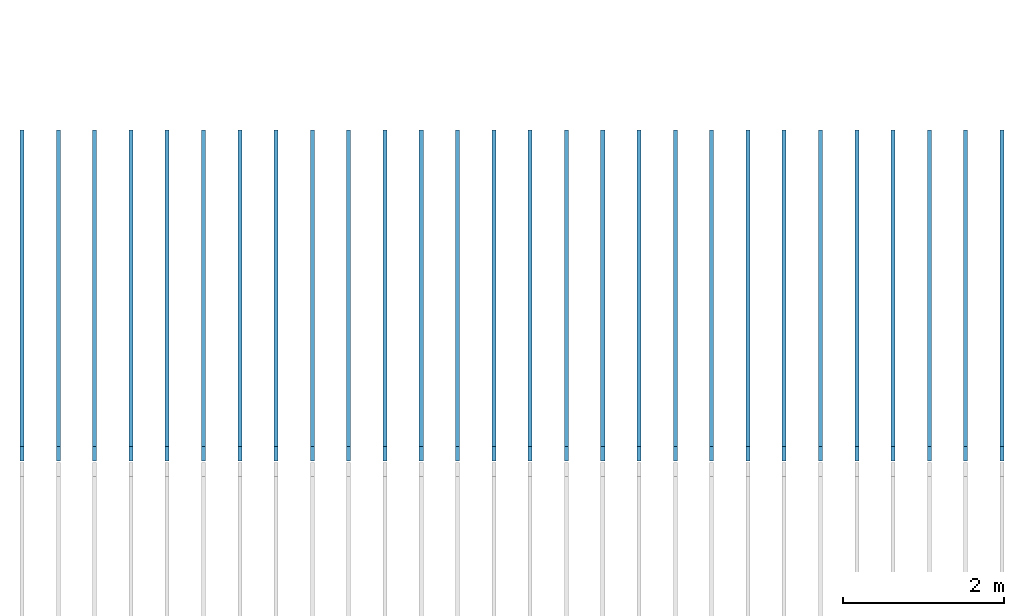
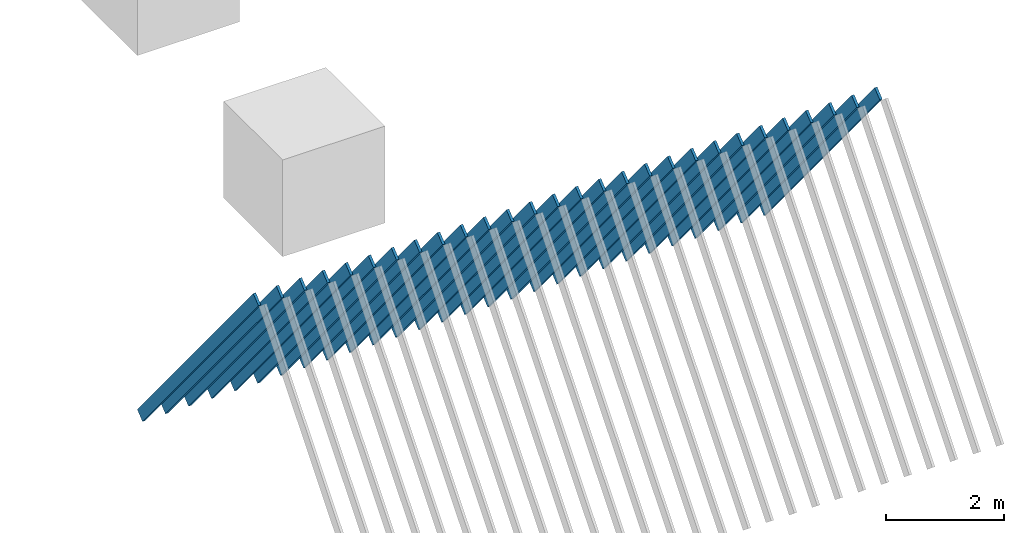
# Not in any storey, part 2 of 4: 1 roof.
"""IFC4 model written with IfcOpenShell, lengths in metres."""

from ifc_helpers import new_model, entity, si_unit, converted_unit, frame, frame_2d, origin_with_axes, place, context, project, polygons, shape, element, save


model = new_model("IFC4")

# Units and contexts
model_context = context("Model", 3, precision=1e-05, world=origin_with_axes())
plan_context = context("Plan", 2, precision=1e-05, world=frame_2d((0.0, 0.0, 0.0), x_axis=(1.0, 0.0, 0.0)))
ifc_project = project(units=[si_unit("AREAUNIT", "SQUARE_METRE"), si_unit("VOLUMEUNIT", "CUBIC_METRE"), si_unit("LENGTHUNIT", "METRE"), converted_unit("PLANEANGLEUNIT", "degree", entity("IfcReal", 0.0174532925199433), si_unit("PLANEANGLEUNIT", "RADIAN"), dimensions=[0, 0, 0, 0, 0, 0, 0])], contexts=[model_context, plan_context])

# Roof
roof_placement = place(None, frame((-7.88622856140137, -10.0965747833252, 4.8522891998291), z_axis=(1.0, -7.11335474079533e-07, -2.5490300004094e-07), x_axis=(-2.5490300004094e-07, -0.635131001472473, 0.772404432296753)))
element("IfcRoof", 1, at=roof_placement, Name="Roof_Joists.001", PredefinedType="BARREL_ROOF", shapes=[
    shape(model_context, None, "Tessellation", [polygons([(3.09032249450684, -0.114181444048882, 0.025000000372529), (3.09032249450684, 0.114181444048882, 0.025000000372529), (-3.09032249450684, -0.114181444048882, 0.025000000372529), (-3.09032249450684, 0.114181444048882, 0.025000000372529), (3.09032249450684, 0.114181444048882, -0.025000000372529), (3.09032249450684, -0.114181444048882, -0.025000000372529), (-3.09032249450684, 0.114181444048882, 0.474999994039536), (3.09032249450684, 0.114181444048882, 0.474999994039536), (-3.09032249450684, 0.114181444048882, 0.424999982118607), (3.09032249450684, 0.114181444048882, 0.424999982118607), (-3.09032249450684, 0.114181444048882, -0.025000000372529), (-3.09032249450684, -0.114181444048882, -0.025000000372529), (3.09032249450684, -0.114181444048882, 0.424999982118607), (-3.09032249450684, -0.114181444048882, 0.424999982118607), (-3.09032249450684, -0.114181444048882, 0.474999994039536), (3.09032249450684, -0.114181444048882, 0.474999994039536), (3.09032249450684, -0.114181444048882, 0.875), (-3.09032249450684, -0.114181444048882, 0.875), (-3.09032249450684, -0.114181444048882, 0.924999952316284), (3.09032249450684, -0.114181444048882, 0.924999952316284), (-3.09032249450684, 0.114181444048882, 0.924999952316284), (3.09032249450684, 0.114181444048882, 0.924999952316284), (-3.09032249450684, 0.114181444048882, 0.875), (3.09032249450684, 0.114181444048882, 0.875), (3.09032249450684, -0.114181444048882, 1.32499992847443), (-3.09032249450684, -0.114181444048882, 1.32499992847443), (-3.09032249450684, -0.114181444048882, 1.37499988079071), (3.09032249450684, -0.114181444048882, 1.37499988079071), (-3.09032249450684, 0.114181444048882, 1.37499988079071), (3.09032249450684, 0.114181444048882, 1.37499988079071), (-3.09032249450684, 0.114181444048882, 1.32499992847443), (3.09032249450684, 0.114181444048882, 1.32499992847443), (3.09032249450684, -0.114181444048882, 1.77499997615814), (-3.09032249450684, -0.114181444048882, 1.77499997615814), (-3.09032249450684, -0.114181444048882, 1.82499992847443), (3.09032249450684, -0.114181444048882, 1.82499992847443), (-3.09032249450684, 0.114181444048882, 1.82499992847443), (3.09032249450684, 0.114181444048882, 1.82499992847443), (-3.09032249450684, 0.114181444048882, 1.77499997615814), (3.09032249450684, 0.114181444048882, 1.77499997615814), (3.09032249450684, -0.114181444048882, 2.27500009536743), (3.09032249450684, 0.114181444048882, 2.27500009536743), (-3.09032249450684, -0.114181444048882, 2.27500009536743), (-3.09032249450684, 0.114181444048882, 2.27500009536743), (-3.09032249450684, 0.114181444048882, 2.72500014305115), (3.09032249450684, 0.114181444048882, 2.72500014305115), (-3.09032249450684, 0.114181444048882, 2.67499995231628), (3.09032249450684, 0.114181444048882, 2.67499995231628), (3.09032249450684, -0.114181444048882, 2.22499990463257), (-3.09032249450684, -0.114181444048882, 2.22499990463257), (3.09032249450684, 0.114181444048882, 2.22499990463257), (-3.09032249450684, 0.114181444048882, 2.22499990463257), (3.09032249450684, -0.114181444048882, 2.67499995231628), (-3.09032249450684, -0.114181444048882, 2.67499995231628), (-3.09032249450684, -0.114181444048882, 2.72500014305115), (3.09032249450684, -0.114181444048882, 2.72500014305115), (3.09032249450684, 0.114181444048882, 4.07500028610229), (3.09032249450684, 0.114181444048882, 4.02500009536743), (-3.09032249450684, 0.114181444048882, 4.07500028610229), (-3.09032249450684, 0.114181444048882, 4.02500009536743), (3.09032249450684, -0.114181444048882, 3.125), (-3.09032249450684, -0.114181444048882, 3.125), (-3.09032249450684, -0.114181444048882, 3.17500019073486), (3.09032249450684, -0.114181444048882, 3.17500019073486), (-3.09032249450684, 0.114181444048882, 3.17500019073486), (3.09032249450684, 0.114181444048882, 3.17500019073486), (-3.09032249450684, 0.114181444048882, 3.125), (3.09032249450684, 0.114181444048882, 3.125), (3.09032249450684, -0.114181444048882, 3.57500004768372), (-3.09032249450684, -0.114181444048882, 3.57500004768372), (-3.09032249450684, -0.114181444048882, 3.62500023841858), (3.09032249450684, -0.114181444048882, 3.62500023841858), (-3.09032249450684, 0.114181444048882, 3.62500023841858), (3.09032249450684, 0.114181444048882, 3.62500023841858), (-3.09032249450684, 0.114181444048882, 3.57500004768372), (3.09032249450684, 0.114181444048882, 3.57500004768372), (3.09032249450684, -0.114181444048882, 4.02500009536743), (-3.09032249450684, -0.114181444048882, 4.02500009536743), (-3.09032249450684, -0.114181444048882, 4.07500028610229), (3.09032249450684, -0.114181444048882, 4.07500028610229), (-3.09032249450684, 0.114181444048882, 4.97499990463257), (3.09032249450684, 0.114181444048882, 4.97499990463257), (-3.09032249450684, 0.114181444048882, 4.92499971389771), (3.09032249450684, 0.114181444048882, 4.92499971389771), (3.09032249450684, -0.114181444048882, 4.52500009536743), (3.09032249450684, 0.114181444048882, 4.52500009536743), (-3.09032249450684, -0.114181444048882, 4.52500009536743), (-3.09032249450684, 0.114181444048882, 4.52500009536743), (3.09032249450684, 0.114181444048882, 4.47499990463257), (-3.09032249450684, 0.114181444048882, 4.47499990463257), (3.09032249450684, -0.114181444048882, 4.47499990463257), (-3.09032249450684, -0.114181444048882, 4.47499990463257), (3.09032249450684, -0.114181444048882, 4.97499990463257), (-3.09032249450684, -0.114181444048882, 4.97499990463257), (3.09032249450684, 0.114181444048882, 9.92499732971191), (3.09032249450684, 0.114181444048882, 9.87499809265137), (-3.09032249450684, 0.114181444048882, 9.92499732971191), (-3.09032249450684, 0.114181444048882, 9.87499809265137), (3.09032249450684, -0.114181444048882, 4.92499971389771), (-3.09032249450684, -0.114181444048882, 4.92499971389771), (3.09032249450684, -0.114181444048882, 5.37499952316284), (-3.09032249450684, -0.114181444048882, 5.37499952316284), (-3.09032249450684, -0.114181444048882, 5.42499971389771), (3.09032249450684, -0.114181444048882, 5.42499971389771), (-3.09032249450684, 0.114181444048882, 5.42499971389771), (3.09032249450684, 0.114181444048882, 5.42499971389771), (-3.09032249450684, 0.114181444048882, 5.37499952316284), (3.09032249450684, 0.114181444048882, 5.37499952316284), (3.09032249450684, -0.114181444048882, 5.87499952316284), (3.09032249450684, 0.114181444048882, 5.87499952316284), (-3.09032249450684, -0.114181444048882, 5.87499952316284), (-3.09032249450684, 0.114181444048882, 5.87499952316284), (-3.09032249450684, 0.114181444048882, 5.82499933242798), (3.09032249450684, 0.114181444048882, 5.82499933242798), (3.09032249450684, -0.114181444048882, 5.82499933242798), (-3.09032249450684, -0.114181444048882, 5.82499933242798), (3.09032249450684, -0.114181444048882, 6.27499914169312), (-3.09032249450684, -0.114181444048882, 6.27499914169312), (-3.09032249450684, -0.114181444048882, 6.32499933242798), (3.09032249450684, -0.114181444048882, 6.32499933242798), (-3.09032249450684, 0.114181444048882, 6.32499933242798), (3.09032249450684, 0.114181444048882, 6.32499933242798), (-3.09032249450684, 0.114181444048882, 6.27499914169312), (3.09032249450684, 0.114181444048882, 6.27499914169312), (3.09032249450684, -0.114181444048882, 6.72499895095825), (-3.09032249450684, -0.114181444048882, 6.72499895095825), (-3.09032249450684, -0.114181444048882, 6.77499914169312), (3.09032249450684, -0.114181444048882, 6.77499914169312), (-3.09032249450684, 0.114181444048882, 6.77499914169312), (3.09032249450684, 0.114181444048882, 6.77499914169312), (-3.09032249450684, 0.114181444048882, 6.72499895095825), (3.09032249450684, 0.114181444048882, 6.72499895095825), (3.09032249450684, -0.114181444048882, 7.17499876022339), (-3.09032249450684, -0.114181444048882, 7.17499876022339), (-3.09032249450684, -0.114181444048882, 7.22499895095825), (3.09032249450684, -0.114181444048882, 7.22499895095825), (-3.09032249450684, 0.114181444048882, 7.22499895095825), (3.09032249450684, 0.114181444048882, 7.22499895095825), (-3.09032249450684, 0.114181444048882, 7.17499876022339), (3.09032249450684, 0.114181444048882, 7.17499876022339), (3.09032249450684, -0.114181444048882, 7.67499876022339), (3.09032249450684, 0.114181444048882, 7.67499876022339), (-3.09032249450684, -0.114181444048882, 7.67499876022339), (-3.09032249450684, 0.114181444048882, 7.67499876022339), (-3.09032249450684, 0.114181444048882, 7.62499856948853), (3.09032249450684, 0.114181444048882, 7.62499856948853), (3.09032249450684, -0.114181444048882, 7.62499856948853), (-3.09032249450684, -0.114181444048882, 7.62499856948853), (3.09032249450684, -0.114181444048882, 8.07499885559082), (-3.09032249450684, -0.114181444048882, 8.07499885559082), (-3.09032249450684, -0.114181444048882, 8.12499809265137), (3.09032249450684, -0.114181444048882, 8.12499809265137), (-3.09032249450684, 0.114181444048882, 8.12499809265137), (3.09032249450684, 0.114181444048882, 8.12499809265137), (-3.09032249450684, 0.114181444048882, 8.07499885559082), (3.09032249450684, 0.114181444048882, 8.07499885559082), (3.09032249450684, -0.114181444048882, 8.52499866485596), (-3.09032249450684, -0.114181444048882, 8.52499866485596), (-3.09032249450684, -0.114181444048882, 8.5749979019165), (3.09032249450684, -0.114181444048882, 8.5749979019165), (-3.09032249450684, 0.114181444048882, 8.5749979019165), (3.09032249450684, 0.114181444048882, 8.5749979019165), (-3.09032249450684, 0.114181444048882, 8.52499866485596), (3.09032249450684, 0.114181444048882, 8.52499866485596), (3.09032249450684, -0.114181444048882, 8.97499847412109), (-3.09032249450684, -0.114181444048882, 8.97499847412109), (-3.09032249450684, -0.114181444048882, 9.02499771118164), (3.09032249450684, -0.114181444048882, 9.02499771118164), (-3.09032249450684, 0.114181444048882, 9.02499771118164), (3.09032249450684, 0.114181444048882, 9.02499771118164), (-3.09032249450684, 0.114181444048882, 8.97499847412109), (3.09032249450684, 0.114181444048882, 8.97499847412109), (3.09032249450684, -0.114181444048882, 9.42499828338623), (-3.09032249450684, -0.114181444048882, 9.42499828338623), (-3.09032249450684, -0.114181444048882, 9.47499752044678), (3.09032249450684, -0.114181444048882, 9.47499752044678), (-3.09032249450684, 0.114181444048882, 9.47499752044678), (3.09032249450684, 0.114181444048882, 9.47499752044678), (-3.09032249450684, 0.114181444048882, 9.42499828338623), (3.09032249450684, 0.114181444048882, 9.42499828338623), (3.09032249450684, -0.114181444048882, 9.92499732971191), (-3.09032249450684, -0.114181444048882, 9.92499732971191), (-3.09032249450684, 0.114181444048882, 10.3749971389771), (3.09032249450684, 0.114181444048882, 10.3749971389771), (-3.09032249450684, 0.114181444048882, 10.3249979019165), (3.09032249450684, 0.114181444048882, 10.3249979019165), (3.09032249450684, -0.114181444048882, 9.87499809265137), (-3.09032249450684, -0.114181444048882, 9.87499809265137), (3.09032249450684, -0.114181444048882, 10.3749971389771), (-3.09032249450684, -0.114181444048882, 10.3749971389771), (3.09032249450684, 0.114181444048882, 10.8249969482422), (3.09032249450684, 0.114181444048882, 10.7749977111816), (-3.09032249450684, 0.114181444048882, 10.8249969482422), (-3.09032249450684, 0.114181444048882, 10.7749977111816), (3.09032249450684, -0.114181444048882, 10.3249979019165), (-3.09032249450684, -0.114181444048882, 10.3249979019165), (3.09032249450684, -0.114181444048882, 10.8249969482422), (-3.09032249450684, -0.114181444048882, 10.8249969482422), (-3.09032249450684, 0.114181444048882, 11.2749967575073), (3.09032249450684, 0.114181444048882, 11.2749967575073), (-3.09032249450684, 0.114181444048882, 11.2249975204468), (3.09032249450684, 0.114181444048882, 11.2249975204468), (3.09032249450684, -0.114181444048882, 10.7749977111816), (-3.09032249450684, -0.114181444048882, 10.7749977111816), (3.09032249450684, -0.114181444048882, 11.2249975204468), (-3.09032249450684, -0.114181444048882, 11.2249975204468), (-3.09032249450684, -0.114181444048882, 11.2749967575073), (3.09032249450684, -0.114181444048882, 11.2749967575073), (3.09032249450684, 0.114181444048882, 11.7249965667725), (3.09032249450684, 0.114181444048882, 11.6749973297119), (-3.09032249450684, 0.114181444048882, 11.7249965667725), (-3.09032249450684, 0.114181444048882, 11.6749973297119), (3.09032249450684, -0.114181444048882, 11.7249965667725), (-3.09032249450684, -0.114181444048882, 11.7249965667725), (3.09032249450684, -0.114181444048882, 11.6749973297119), (-3.09032249450684, -0.114181444048882, 11.6749973297119), (3.09032249450684, -0.114181444048882, 12.1249971389771), (-3.09032249450684, -0.114181444048882, 12.1249971389771), (-3.09032249450684, -0.114181444048882, 12.1749963760376), (3.09032249450684, -0.114181444048882, 12.1749963760376), (-3.09032249450684, 0.114181444048882, 12.1749963760376), (-3.09032249450684, 0.114181444048882, 12.1249971389771), (3.09032249450684, 0.114181444048882, 12.1249971389771), (3.09032249450684, 0.114181444048882, 12.1749963760376)], [[[14, 9, 10, 13]], [[47, 54, 55, 45]], [[21, 22, 24, 23]], [[46, 56, 53, 48]], [[18, 17, 20, 19]], [[131, 126, 127, 129]], [[18, 23, 24, 17]], [[29, 30, 32, 31]], [[30, 28, 25, 32]], [[26, 25, 28, 27]], [[28, 30, 29, 27]], [[26, 31, 32, 25]], [[37, 38, 40, 39]], [[39, 34, 35, 37]], [[38, 36, 33, 40]], [[34, 33, 36, 35]], [[36, 38, 37, 35]], [[34, 39, 40, 33]], [[45, 46, 48, 47]], [[80, 57, 59, 79]], [[41, 42, 44, 43]], [[42, 41, 49, 51]], [[44, 42, 51, 52]], [[50, 49, 41, 43]], [[66, 64, 61, 68]], [[65, 66, 68, 67]], [[59, 57, 58, 60]], [[136, 138, 137, 135]], [[85, 86, 88, 87]], [[62, 61, 64, 63]], [[78, 60, 58, 77]], [[67, 62, 63, 65]], [[54, 53, 56, 55]], [[64, 66, 65, 63]], [[123, 118, 119, 121]], [[62, 67, 68, 61]], [[73, 74, 76, 75]], [[75, 70, 71, 73]], [[74, 72, 69, 76]], [[70, 69, 72, 71]], [[72, 74, 73, 71]], [[70, 75, 76, 69]], [[57, 80, 77, 58]], [[90, 92, 87, 88]], [[79, 78, 77, 80]], [[86, 85, 91, 89]], [[88, 86, 89, 90]], [[52, 50, 43, 44]], [[82, 93, 99, 84]], [[100, 83, 84, 99]], [[92, 90, 89, 91]], [[83, 81, 82, 84]], [[83, 100, 94, 81]], [[92, 91, 85, 87]], [[97, 95, 96, 98]], [[100, 99, 93, 94]], [[102, 101, 104, 103]], [[93, 82, 81, 94]], [[107, 102, 103, 105]], [[105, 106, 108, 107]], [[104, 106, 105, 103]], [[106, 104, 101, 108]], [[116, 113, 114, 115]], [[212, 216, 214, 211]], [[213, 209, 211, 214]], [[102, 107, 108, 101]], [[121, 122, 124, 123]], [[113, 116, 111, 112]], [[109, 110, 112, 111]], [[113, 112, 110, 114]], [[120, 122, 121, 119]], [[116, 115, 109, 111]], [[110, 109, 115, 114]], [[122, 120, 117, 124]], [[118, 117, 120, 119]], [[208, 200, 199, 207]], [[56, 46, 45, 55]], [[118, 123, 124, 117]], [[129, 130, 132, 131]], [[16, 8, 7, 15]], [[130, 128, 125, 132]], [[126, 125, 128, 127]], [[128, 130, 129, 127]], [[126, 131, 132, 125]], [[137, 138, 140, 139]], [[139, 134, 135, 137]], [[138, 136, 133, 140]], [[134, 133, 136, 135]], [[50, 52, 51, 49]], [[134, 139, 140, 133]], [[153, 154, 156, 155]], [[145, 148, 143, 144]], [[141, 142, 144, 143]], [[145, 144, 142, 146]], [[152, 154, 153, 151]], [[148, 147, 141, 143]], [[142, 141, 147, 146]], [[154, 152, 149, 156]], [[150, 149, 152, 151]], [[98, 188, 182, 97]], [[155, 150, 151, 153]], [[150, 155, 156, 149]], [[161, 162, 164, 163]], [[163, 158, 159, 161]], [[162, 160, 157, 164]], [[158, 157, 160, 159]], [[160, 162, 161, 159]], [[158, 163, 164, 157]], [[169, 170, 172, 171]], [[171, 166, 167, 169]], [[170, 168, 165, 172]], [[166, 165, 168, 167]], [[168, 170, 169, 167]], [[166, 171, 172, 165]], [[177, 178, 180, 179]], [[179, 174, 175, 177]], [[178, 176, 173, 180]], [[174, 173, 176, 175]], [[176, 178, 177, 175]], [[174, 179, 180, 173]], [[181, 95, 97, 182]], [[95, 181, 187, 96]], [[188, 187, 181, 182]], [[206, 205, 208, 207]], [[185, 183, 184, 186]], [[185, 196, 190, 183]], [[188, 98, 96, 187]], [[196, 195, 189, 190]], [[189, 184, 183, 190]], [[193, 191, 192, 194]], [[196, 185, 186, 195]], [[199, 200, 202, 201]], [[184, 189, 195, 186]], [[204, 203, 197, 198]], [[204, 194, 192, 203]], [[194, 204, 198, 193]], [[197, 191, 193, 198]], [[201, 206, 207, 199]], [[191, 197, 203, 192]], [[216, 215, 213, 214]], [[8, 16, 13, 10]], [[1, 2, 4, 3]], [[206, 201, 202, 205]], [[7, 8, 10, 9]], [[216, 212, 210, 215]], [[209, 213, 215, 210]], [[12, 6, 1, 3]], [[211, 209, 210, 212]], [[148, 145, 146, 147]], [[222, 218, 219, 221]], [[60, 78, 79, 59]], [[221, 224, 223, 222]], [[224, 220, 217, 223]], [[218, 217, 220, 219]], [[219, 224, 221]], [[222, 217, 218]], [[22, 20, 17, 24]], [[4, 2, 5, 11]], [[6, 5, 2, 1]], [[3, 4, 11, 12]], [[12, 11, 5, 6]], [[54, 47, 48, 53]], [[31, 26, 27, 29]], [[9, 14, 15, 7]], [[23, 18, 19, 21]], [[20, 22, 21, 19]], [[14, 13, 16, 15]], [[200, 208, 205, 202]], [[219, 220, 224]], [[222, 223, 217]]])]),
])

save(model, "model.ifc")
